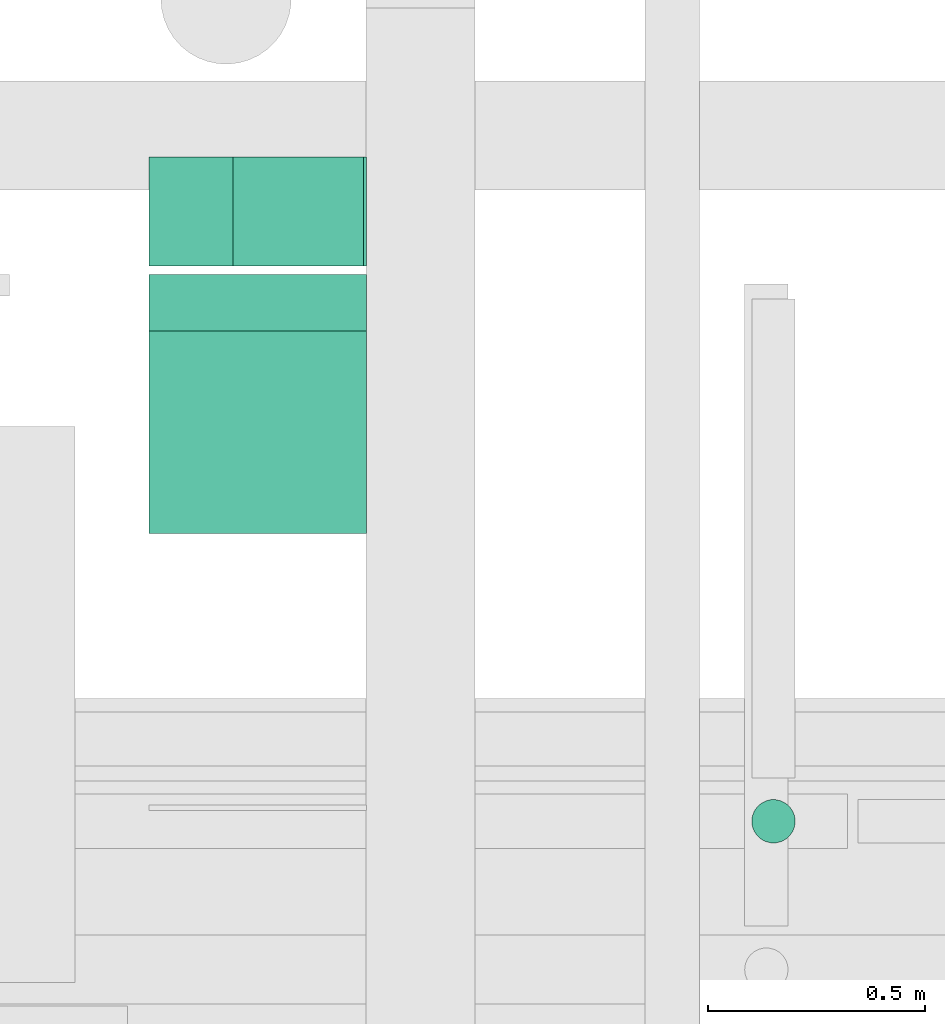
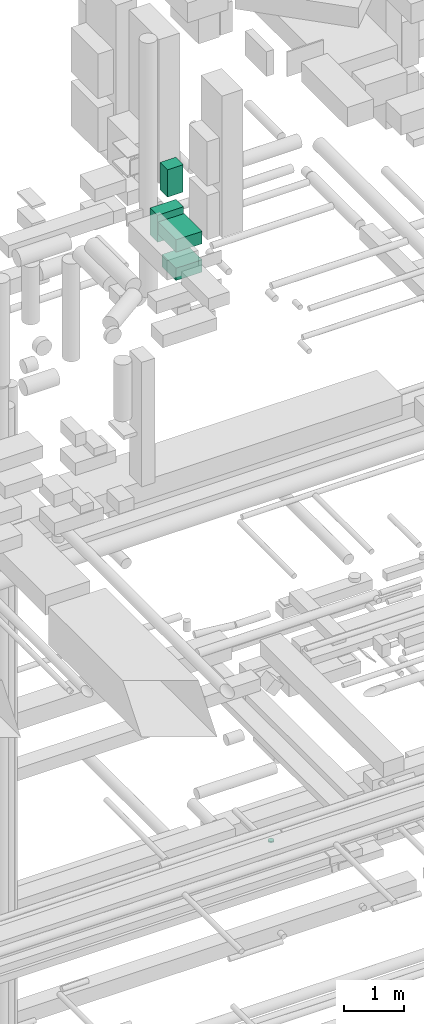
# One storey, part 143 of 337: 5 flow segments.
"""IFC2X3 building model written with IfcOpenShell, lengths in millimetres."""

from ifc_helpers import new_model, entity, si_unit, converted_unit, derived_unit, direction, frame, origin, origin_2d_with_axis, place, context, subcontext, project, spatial, rectangle, circle, extrude, type_object, element, save


model = new_model("IFC2X3")

# Units and contexts
model_context = context("Model", 3, precision=0.01, world=origin(), true_north=direction((6.12303176911189e-17, 1.0)))
body_context = subcontext(model_context, "Body", "Model", "MODEL_VIEW")
ifc_project = project(units=[si_unit("LENGTHUNIT", "METRE", prefix="MILLI"), si_unit("AREAUNIT", "SQUARE_METRE"), si_unit("VOLUMEUNIT", "CUBIC_METRE"), converted_unit("PLANEANGLEUNIT", "DEGREE", entity("IfcRatioMeasure", 0.0174532925199433), si_unit("PLANEANGLEUNIT", "RADIAN"), dimensions=[0, 0, 0, 0, 0, 0, 0]), si_unit("MASSUNIT", "GRAM", prefix="KILO"), derived_unit("MASSDENSITYUNIT", [(si_unit("MASSUNIT", "GRAM", prefix="KILO"), 1), (si_unit("LENGTHUNIT", "METRE"), -3)]), derived_unit("MOMENTOFINERTIAUNIT", [(si_unit("LENGTHUNIT", "METRE"), 4)]), si_unit("TIMEUNIT", "SECOND"), si_unit("FREQUENCYUNIT", "HERTZ"), si_unit("THERMODYNAMICTEMPERATUREUNIT", "DEGREE_CELSIUS"), derived_unit("THERMALTRANSMITTANCEUNIT", [(si_unit("MASSUNIT", "GRAM", prefix="KILO"), 1), (si_unit("THERMODYNAMICTEMPERATUREUNIT", "KELVIN"), -1), (si_unit("TIMEUNIT", "SECOND"), -3)]), derived_unit("VOLUMETRICFLOWRATEUNIT", [(si_unit("LENGTHUNIT", "METRE"), 3), (si_unit("TIMEUNIT", "SECOND"), -1)]), derived_unit("MASSFLOWRATEUNIT", [(si_unit("MASSUNIT", "GRAM", prefix="KILO"), 1), (si_unit("TIMEUNIT", "SECOND"), -1)]), derived_unit("ROTATIONALFREQUENCYUNIT", [(si_unit("TIMEUNIT", "SECOND"), -1)]), si_unit("ELECTRICCURRENTUNIT", "AMPERE"), si_unit("ELECTRICVOLTAGEUNIT", "VOLT"), si_unit("POWERUNIT", "WATT"), si_unit("FORCEUNIT", "NEWTON", prefix="KILO"), si_unit("ILLUMINANCEUNIT", "LUX"), si_unit("LUMINOUSFLUXUNIT", "LUMEN"), si_unit("LUMINOUSINTENSITYUNIT", "CANDELA"), derived_unit("USERDEFINED", [(si_unit("MASSUNIT", "GRAM", prefix="KILO"), -1), (si_unit("LENGTHUNIT", "METRE"), -2), (si_unit("TIMEUNIT", "SECOND"), 3), (si_unit("LUMINOUSFLUXUNIT", "LUMEN"), 1)]), derived_unit("LINEARVELOCITYUNIT", [(si_unit("LENGTHUNIT", "METRE"), 1), (si_unit("TIMEUNIT", "SECOND"), -1)]), si_unit("PRESSUREUNIT", "PASCAL"), derived_unit("USERDEFINED", [(si_unit("LENGTHUNIT", "METRE"), -2), (si_unit("MASSUNIT", "GRAM", prefix="KILO"), 1), (si_unit("TIMEUNIT", "SECOND"), -2)]), derived_unit("LINEARFORCEUNIT", [(si_unit("MASSUNIT", "GRAM", prefix="KILO"), 1), (si_unit("LENGTHUNIT", "METRE"), 1), (si_unit("TIMEUNIT", "SECOND"), -2), (si_unit("LENGTHUNIT", "METRE"), -1)]), derived_unit("PLANARFORCEUNIT", [(si_unit("MASSUNIT", "GRAM", prefix="KILO"), 1), (si_unit("LENGTHUNIT", "METRE"), 1), (si_unit("TIMEUNIT", "SECOND"), -2), (si_unit("LENGTHUNIT", "METRE"), -2)])], contexts=[model_context])

# Site, building, storey
site_placement = place(None, origin())
site = spatial("IfcSite", under=ifc_project, at=site_placement, CompositionType="ELEMENT")
building_placement = place(site_placement, origin())
building = spatial("IfcBuilding", under=site, at=building_placement, CompositionType="ELEMENT")
storey_placement = place(building_placement, origin())
storey = spatial("IfcBuildingStorey", under=building, at=storey_placement, CompositionType="ELEMENT", Elevation=0.0)

# Flow segments
duct_segment_type_1 = type_object("IfcDuctSegmentType", PredefinedType="NOTDEFINED")
flow_segment_1_placement = place(storey_placement, frame((35581.06, 10005.52, 19140.0)))
element("IfcFlowSegment", 1, at=flow_segment_1_placement, inside=storey, type_object=duct_segment_type_1, context=body_context, shape_type="SweptSolid", body=[
    extrude(circle(Radius=50.0, at=origin_2d_with_axis()), frame((51.6, 51.6, 0.0), z_axis=(0.0, 0.0, 1.0), x_axis=(-1.0, 0.0, 0.0)), (0.0, 0.0, 1.0), 27.4999999999244),
])
duct_segment_type_2 = type_object("IfcDuctSegmentType", PredefinedType="NOTDEFINED")
flow_segment_2_placement = place(storey_placement, frame((34388.64, 11335.54, 31849.26)))
element("IfcFlowSegment", 2, at=flow_segment_2_placement, inside=storey, type_object=duct_segment_type_2, context=body_context, shape_type="SweptSolid", body=[
    extrude(rectangle(XDim=300.000000000001, YDim=249.999999999999, at=origin_2d_with_axis()), frame((150.0, 125.0, 0.0)), (0.0, 0.0, 1.0), 555.742030997981),
])
flow_segment_3_placement = place(storey_placement, frame((34195.98, 11335.54, 31000.0)))
element("IfcFlowSegment", 3, at=flow_segment_3_placement, inside=storey, type_object=duct_segment_type_2, context=body_context, shape_type="SweptSolid", body=[
    extrude(rectangle(XDim=499.999999999999, YDim=249.999999999999, at=origin_2d_with_axis()), frame((250.0, 125.0, 0.0)), (0.0, 0.0, 1.0), 549.257969002024),
])
flow_segment_4_placement = place(storey_placement, frame((34195.98, 10719.36, 31175.0)))
element("IfcFlowSegment", 4, at=flow_segment_4_placement, inside=storey, type_object=duct_segment_type_2, context=body_context, shape_type="SweptSolid", body=[
    extrude(rectangle(XDim=596.172007283308, YDim=499.999999999999, at=origin_2d_with_axis()), frame((250.0, 298.09, 0.0), z_axis=(0.0, 0.0, 1.0), x_axis=(0.0, -1.0, 0.0)), (0.0, 0.0, 1.0), 250.000000000004),
])
flow_segment_5_placement = place(storey_placement, frame((34195.98, 10719.68, 30600.0)))
element("IfcFlowSegment", 5, at=flow_segment_5_placement, inside=storey, type_object=duct_segment_type_2, context=body_context, shape_type="SweptSolid", body=[
    extrude(rectangle(XDim=465.852653143115, YDim=499.999999999999, at=origin_2d_with_axis()), frame((250.0, 232.93, 0.0), z_axis=(0.0, 0.0, 1.0), x_axis=(0.0, -1.0, 0.0)), (0.0, 0.0, 1.0), 250.000000000004),
])

save(model, "model.ifc")
